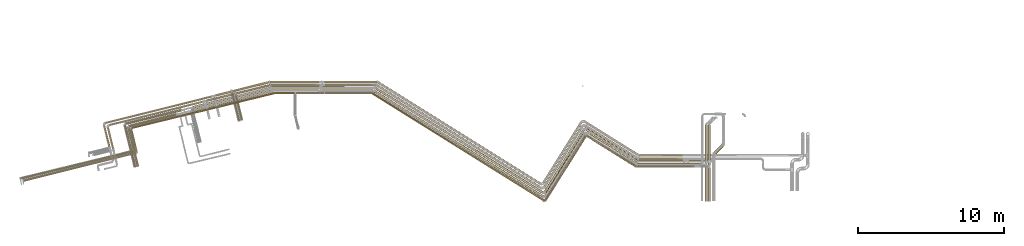
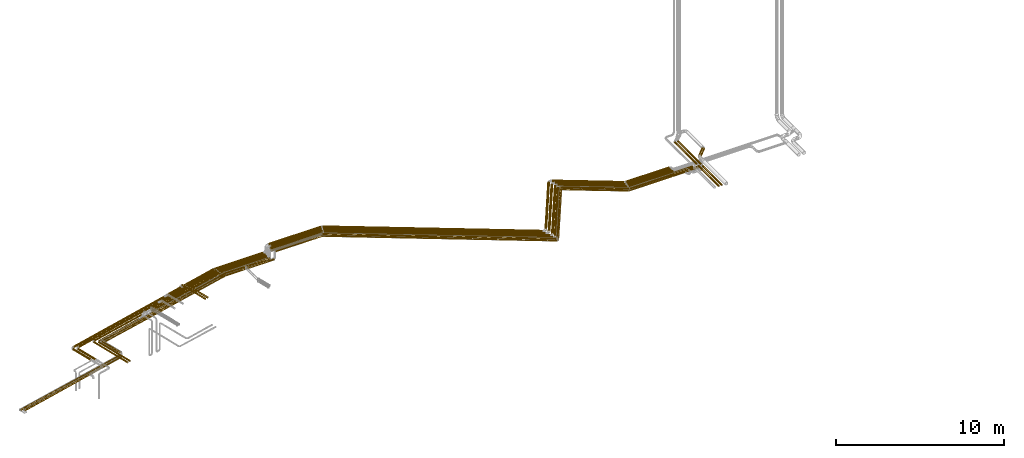
# One storey, part 1 of 93: 65 coverings.
"""IFC2X3 building model written with IfcOpenShell, lengths in millimetres."""

from ifc_helpers import new_model, entity, si_unit, converted_unit, derived_unit, direction, frame, origin, origin_2d_with_axis, place, context, subcontext, project, spatial, circle, extrude, element, save


model = new_model("IFC2X3")

# Units and contexts
model_context = context("Model", 3, precision=0.01, world=origin(), true_north=direction((6.12303176911189e-17, 1.0)))
body_context = subcontext(model_context, "Body", "Model", "MODEL_VIEW")
ifc_project = project(units=[si_unit("LENGTHUNIT", "METRE", prefix="MILLI"), si_unit("AREAUNIT", "SQUARE_METRE"), si_unit("VOLUMEUNIT", "CUBIC_METRE"), converted_unit("PLANEANGLEUNIT", "DEGREE", entity("IfcRatioMeasure", 0.0174532925199433), si_unit("PLANEANGLEUNIT", "RADIAN"), dimensions=[0, 0, 0, 0, 0, 0, 0]), si_unit("MASSUNIT", "GRAM", prefix="KILO"), derived_unit("MASSDENSITYUNIT", [(si_unit("MASSUNIT", "GRAM", prefix="KILO"), 1), (si_unit("LENGTHUNIT", "METRE"), -3)]), derived_unit("MOMENTOFINERTIAUNIT", [(si_unit("LENGTHUNIT", "METRE"), 4)]), si_unit("TIMEUNIT", "SECOND"), si_unit("FREQUENCYUNIT", "HERTZ"), si_unit("THERMODYNAMICTEMPERATUREUNIT", "DEGREE_CELSIUS"), derived_unit("THERMALTRANSMITTANCEUNIT", [(si_unit("MASSUNIT", "GRAM", prefix="KILO"), 1), (si_unit("THERMODYNAMICTEMPERATUREUNIT", "KELVIN"), -1), (si_unit("TIMEUNIT", "SECOND"), -3)]), derived_unit("VOLUMETRICFLOWRATEUNIT", [(si_unit("LENGTHUNIT", "METRE"), 3), (si_unit("TIMEUNIT", "SECOND"), -1)]), derived_unit("MASSFLOWRATEUNIT", [(si_unit("MASSUNIT", "GRAM", prefix="KILO"), 1), (si_unit("TIMEUNIT", "SECOND"), -1)]), derived_unit("ROTATIONALFREQUENCYUNIT", [(si_unit("TIMEUNIT", "SECOND"), -1)]), si_unit("ELECTRICCURRENTUNIT", "AMPERE"), si_unit("ELECTRICVOLTAGEUNIT", "VOLT"), si_unit("POWERUNIT", "WATT"), si_unit("FORCEUNIT", "NEWTON", prefix="KILO"), si_unit("ILLUMINANCEUNIT", "LUX"), si_unit("LUMINOUSFLUXUNIT", "LUMEN"), si_unit("LUMINOUSINTENSITYUNIT", "CANDELA"), derived_unit("USERDEFINED", [(si_unit("MASSUNIT", "GRAM", prefix="KILO"), -1), (si_unit("LENGTHUNIT", "METRE"), -2), (si_unit("TIMEUNIT", "SECOND"), 3), (si_unit("LUMINOUSFLUXUNIT", "LUMEN"), 1)]), derived_unit("LINEARVELOCITYUNIT", [(si_unit("LENGTHUNIT", "METRE"), 1), (si_unit("TIMEUNIT", "SECOND"), -1)]), si_unit("PRESSUREUNIT", "PASCAL"), derived_unit("USERDEFINED", [(si_unit("LENGTHUNIT", "METRE"), -2), (si_unit("MASSUNIT", "GRAM", prefix="KILO"), 1), (si_unit("TIMEUNIT", "SECOND"), -2)]), derived_unit("LINEARFORCEUNIT", [(si_unit("MASSUNIT", "GRAM", prefix="KILO"), 1), (si_unit("LENGTHUNIT", "METRE"), 1), (si_unit("TIMEUNIT", "SECOND"), -2), (si_unit("LENGTHUNIT", "METRE"), -1)]), derived_unit("PLANARFORCEUNIT", [(si_unit("MASSUNIT", "GRAM", prefix="KILO"), 1), (si_unit("LENGTHUNIT", "METRE"), 1), (si_unit("TIMEUNIT", "SECOND"), -2), (si_unit("LENGTHUNIT", "METRE"), -2)])], contexts=[model_context])

# Site, building, storey
site_placement = place(None, origin())
site = spatial("IfcSite", under=ifc_project, at=site_placement, CompositionType="ELEMENT")
building_placement = place(site_placement, origin())
building = spatial("IfcBuilding", under=site, at=building_placement, CompositionType="ELEMENT")
storey_placement = place(building_placement, frame((0.0, 0.0, -4200.0)))
storey = spatial("IfcBuildingStorey", under=building, at=storey_placement, CompositionType="ELEMENT", Elevation=-4200.0)

# Coverings
covering_1_placement = place(storey_placement, frame((16223.6, 8804.96, 2914.66)))
element("IfcCovering", 1, at=covering_1_placement, inside=storey, Name=":ADSK_", ObjectType=":ADSK_", PredefinedType="INSULATION", context=body_context, shape_type="SweptSolid", body=[
    extrude(circle(Radius=84.5, at=origin_2d_with_axis()), frame((3445.16, 73.26, 86.1), z_axis=(-0.848048096872166, 0.529919263087781, 0.0), x_axis=(-0.529919263087781, -0.848048096872166, 0.0)), (0.0, 0.0, 1.0), 4007.77716045076),
])
covering_2_placement = place(storey_placement, frame((13365.87, 6651.78, 2914.66)))
element("IfcCovering", 2, at=covering_2_placement, inside=storey, Name=":ADSK_", ObjectType=":ADSK_", PredefinedType="INSULATION", context=body_context, shape_type="SweptSolid", body=[
    extrude(circle(Radius=84.5, at=origin_2d_with_axis()), frame((73.26, 46.37, 86.1), z_axis=(0.529919264233208, 0.848048096156424, 0.0), x_axis=(0.848048096156424, -0.529919264233208, 0.0)), (0.0, 0.0, 1.0), 5029.99999999998),
])
covering_3_placement = place(storey_placement, frame((1670.12, 6586.73, 2913.9)))
element("IfcCovering", 3, at=covering_3_placement, inside=storey, Name=":ADSK_", ObjectType=":ADSK_", PredefinedType="INSULATION", context=body_context, shape_type="SweptSolid", body=[
    extrude(circle(Radius=84.5, at=origin_2d_with_axis()), frame((11603.65, 73.26, 86.85), z_axis=(-0.848048094870504, 0.529919263429674, -5.5069602747006e-05), x_axis=(0.529919264233207, 0.848048096156425, 0.0)), (0.0, 0.0, 1.0), 13628.0909050597),
])
covering_4_placement = place(storey_placement, frame((-1871.09, 13813.91, 2913.9)))
element("IfcCovering", 4, at=covering_4_placement, inside=storey, Name=":ADSK_", ObjectType=":ADSK_", PredefinedType="INSULATION", context=body_context, shape_type="SweptSolid", body=[
    extrude(circle(Radius=84.5, at=origin_2d_with_axis()), frame((0.0, 86.1, 86.1), z_axis=(1.0, 0.0, -7.50758540454034e-07), x_axis=(0.0, -1.0, 0.0)), (0.0, 0.0, 1.0), 3523.99516441944),
])
covering_5_placement = place(storey_placement, frame((19732.35, 8773.89, 2914.66)))
element("IfcCovering", 5, at=covering_5_placement, inside=storey, Name=":ADSK_", ObjectType=":ADSK_", PredefinedType="INSULATION", context=body_context, shape_type="SweptSolid", body=[
    extrude(circle(Radius=84.5, at=origin_2d_with_axis()), frame((0.0, 86.1, 86.1), z_axis=(1.0, 0.0, 0.0), x_axis=(0.0, -1.0, 0.0)), (0.0, 0.0, 1.0), 4364.44138685684),
])
covering_6_placement = place(storey_placement, frame((24958.04, 9544.49, 2891.9)))
element("IfcCovering", 6, at=covering_6_placement, inside=storey, Name=":ADSK_", ObjectType=":ADSK_", PredefinedType="INSULATION", context=body_context, shape_type="SweptSolid", body=[
    extrude(circle(Radius=106.5, at=origin_2d_with_axis()), frame((76.9, 76.9, 108.1), z_axis=(0.707106781186553, 0.707106781186542, 0.0), x_axis=(-0.707106781186542, 0.707106781186553, 0.0)), (0.0, 0.0, 1.0), 775.735931288089),
])
covering_7_placement = place(storey_placement, frame((19790.5, 8975.05, 2910.91)))
element("IfcCovering", 7, at=covering_7_placement, inside=storey, Name=":ADSK_", ObjectType=":ADSK_", PredefinedType="INSULATION", context=body_context, shape_type="SweptSolid", body=[
    extrude(circle(Radius=84.5, at=origin_2d_with_axis()), frame((0.0, 86.1, 86.1), z_axis=(1.0, 0.0, 0.0), x_axis=(0.0, 1.0, 0.0)), (0.0, 0.0, 1.0), 3082.63986313707),
])
covering_8_placement = place(storey_placement, frame((16181.84, 9006.12, 2910.91)))
element("IfcCovering", 8, at=covering_8_placement, inside=storey, Name=":ADSK_", ObjectType=":ADSK_", PredefinedType="INSULATION", context=body_context, shape_type="SweptSolid", body=[
    extrude(circle(Radius=84.5, at=origin_2d_with_axis()), frame((3545.07, 73.26, 86.1), z_axis=(-0.848048096872165, 0.529919263087784, 0.0), x_axis=(-0.529919263087784, -0.848048096872165, 0.0)), (0.0, 0.0, 1.0), 4125.59056056346),
])
covering_9_placement = place(storey_placement, frame((13334.7, 6932.33, 2910.91)))
element("IfcCovering", 9, at=covering_9_placement, inside=storey, Name=":ADSK_", ObjectType=":ADSK_", PredefinedType="INSULATION", context=body_context, shape_type="SweptSolid", body=[
    extrude(circle(Radius=84.5, at=origin_2d_with_axis()), frame((73.26, 46.37, 86.1), z_axis=(0.529919264233209, 0.848048096156423, 0.0), x_axis=(0.848048096156423, -0.529919264233209, 0.0)), (0.0, 0.0, 1.0), 5010.0017049427),
])
covering_10_placement = place(storey_placement, frame((1774.02, 6867.28, 2910.91)))
element("IfcCovering", 10, at=covering_10_placement, inside=storey, Name=":ADSK_", ObjectType=":ADSK_", PredefinedType="INSULATION", context=body_context, shape_type="SweptSolid", body=[
    extrude(circle(Radius=84.5, at=origin_2d_with_axis()), frame((11468.58, 73.26, 86.1), z_axis=(-0.848048096156424, 0.529919264233208, 0.0), x_axis=(0.0, 0.0, -1.0)), (0.0, 0.0, 1.0), 13468.8235901615),
])
covering_11_placement = place(storey_placement, frame((-1834.92, 14010.06, 2910.94)))
element("IfcCovering", 11, at=covering_11_placement, inside=storey, Name=":ADSK_", ObjectType=":ADSK_", PredefinedType="INSULATION", context=body_context, shape_type="SweptSolid", body=[
    extrude(circle(Radius=84.5, at=origin_2d_with_axis()), frame((3591.85, 86.1, 86.1), z_axis=(-0.99999896917087, 0.00107763060458495, 0.000948878009774168), x_axis=(-0.00107763108971813, -0.999999419355449, 0.0)), (0.0, 0.0, 1.0), 3590.17075330023),
])
covering_12_placement = place(storey_placement, frame((-7764.06, 13646.82, 2416.82)))
element("IfcCovering", 12, at=covering_12_placement, inside=storey, Name=":ADSK_", ObjectType=":ADSK_", PredefinedType="INSULATION", context=body_context, shape_type="SweptSolid", body=[
    extrude(circle(Radius=81.5, at=origin_2d_with_axis()), frame((20.9, 80.78, 83.1), z_axis=(0.971553061175066, 0.236821975409198, 3.58419250346389e-05), x_axis=(0.236821975561314, -0.971553061799116, 0.0)), (0.0, 0.0, 1.0), 2394.20471743284),
])
covering_13_placement = place(storey_placement, frame((-16451.83, 11492.29, 2429.32)))
element("IfcCovering", 13, at=covering_13_placement, inside=storey, Name=":ADSK_", ObjectType=":ADSK_", PredefinedType="INSULATION", context=body_context, shape_type="SweptSolid", body=[
    extrude(circle(Radius=69.0, at=origin_2d_with_axis()), frame((18.29, 68.55, 70.6), z_axis=(0.970295726276005, 0.241921895599632, 0.0), x_axis=(-0.241921895599632, 0.970295726276005, 0.0)), (0.0, 0.0, 1.0), 6535.06575644785),
])
covering_14_placement = place(storey_placement, frame((-7831.89, 11898.55, 2654.9)))
element("IfcCovering", 14, at=covering_14_placement, inside=storey, Name=":ADSK_", ObjectType=":ADSK_", PredefinedType="INSULATION", context=body_context, shape_type="SweptSolid", body=[
    extrude(circle(Radius=43.5, at=origin_2d_with_axis()), frame((43.8, 1740.55, 45.1), z_axis=(0.241921895599631, -0.970295726276006, 0.0), x_axis=(0.970295726276006, 0.241921895599631, 0.0)), (0.0, 0.0, 1.0), 1781.33959077582),
])
covering_15_placement = place(storey_placement, frame((-9803.41, 13138.56, 2416.82)))
element("IfcCovering", 15, at=covering_15_placement, inside=storey, Name=":ADSK_", ObjectType=":ADSK_", PredefinedType="INSULATION", context=body_context, shape_type="SweptSolid", body=[
    extrude(circle(Radius=81.5, at=origin_2d_with_axis()), frame((21.31, 80.67, 83.1), z_axis=(0.970295726276001, 0.241921895599651, 0.0), x_axis=(-0.171064612896004, 0.686102687806091, 0.707106781186546)), (0.0, 0.0, 1.0), 1971.35839123397),
])
covering_16_placement = place(storey_placement, frame((-5372.07, 14216.91, 2416.9)))
element("IfcCovering", 16, at=covering_16_placement, inside=storey, Name=":ADSK_", ObjectType=":ADSK_", PredefinedType="INSULATION", context=body_context, shape_type="SweptSolid", body=[
    extrude(circle(Radius=81.5, at=origin_2d_with_axis()), frame((0.0, 83.1, 83.1), z_axis=(1.0, 0.0, 0.0), x_axis=(0.0, 1.0, 0.0)), (0.0, 0.0, 1.0), 3329.8857023589),
])
covering_17_placement = place(storey_placement, frame((1863.72, 7196.14, 2916.9)))
element("IfcCovering", 17, at=covering_17_placement, inside=storey, Name=":ADSK_", ObjectType=":ADSK_", PredefinedType="INSULATION", context=body_context, shape_type="SweptSolid", body=[
    extrude(circle(Radius=81.5, at=origin_2d_with_axis()), frame((44.78, 7074.99, 83.1), z_axis=(0.848048096156426, -0.529919264233205, 0.0), x_axis=(0.529919264233205, 0.848048096156426, 0.0)), (0.0, 0.0, 1.0), 13217.6368280217),
])
covering_18_placement = place(storey_placement, frame((13308.79, 7282.51, 2916.9)))
element("IfcCovering", 18, at=covering_18_placement, inside=storey, Name=":ADSK_", ObjectType=":ADSK_", PredefinedType="INSULATION", context=body_context, shape_type="SweptSolid", body=[
    extrude(circle(Radius=81.5, at=origin_2d_with_axis()), frame((70.71, 44.78, 83.1), z_axis=(0.529919264233208, 0.848048096156424, 0.0), x_axis=(-0.848048096156424, 0.529919264233208, 0.0)), (0.0, 0.0, 1.0), 4839.99999995205),
])
covering_19_placement = place(storey_placement, frame((16161.34, 9212.9, 2916.9)))
element("IfcCovering", 19, at=covering_19_placement, inside=storey, Name=":ADSK_", ObjectType=":ADSK_", PredefinedType="INSULATION", context=body_context, shape_type="SweptSolid", body=[
    extrude(circle(Radius=81.5, at=origin_2d_with_axis()), frame((3579.42, 70.71, 83.1), z_axis=(-0.848048096156425, 0.529919264233206, 0.0), x_axis=(0.529919264233206, 0.848048096156425, 0.0)), (0.0, 0.0, 1.0), 4167.96244380158),
])
covering_20_placement = place(storey_placement, frame((19841.45, 9171.64, 2916.9)))
element("IfcCovering", 20, at=covering_20_placement, inside=storey, Name=":ADSK_", ObjectType=":ADSK_", PredefinedType="INSULATION", context=body_context, shape_type="SweptSolid", body=[
    extrude(circle(Radius=81.5, at=origin_2d_with_axis()), frame((0.0, 83.1, 83.1), z_axis=(1.0, 0.0, 0.0), x_axis=(0.0, 1.0, 0.0)), (0.0, 0.0, 1.0), 3011.72234269005),
])
covering_21_placement = place(storey_placement, frame((24403.45, 8937.14, 2935.4)))
element("IfcCovering", 21, at=covering_21_placement, inside=storey, Name=":ADSK_", ObjectType=":ADSK_", PredefinedType="INSULATION", context=body_context, shape_type="SweptSolid", body=[
    extrude(circle(Radius=63.0, at=origin_2d_with_axis()), frame((64.6, 0.0, 64.6), z_axis=(0.0, 1.0, 0.0), x_axis=(-1.0, 0.0, 0.0)), (0.0, 0.0, 1.0), 2647.17830176069),
])
covering_22_placement = place(storey_placement, frame((24403.45, 6345.74, 2935.4)))
element("IfcCovering", 22, at=covering_22_placement, inside=storey, Name=":ADSK_", ObjectType=":ADSK_", PredefinedType="INSULATION", context=body_context, shape_type="SweptSolid", body=[
    extrude(circle(Radius=63.0, at=origin_2d_with_axis()), frame((64.6, 0.0, 64.6), z_axis=(0.0, 1.0, 0.0), x_axis=(-1.0, 0.0, 0.0)), (0.0, 0.0, 1.0), 2439.40034200199),
])
covering_23_placement = place(storey_placement, frame((19661.55, 8660.55, 2892.25)))
element("IfcCovering", 23, at=covering_23_placement, inside=storey, Name=":ADSK_", ObjectType=":ADSK_", PredefinedType="INSULATION", context=body_context, shape_type="SweptSolid", body=[
    extrude(circle(Radius=49.0, at=origin_2d_with_axis()), frame((0.0, 50.6, 50.6), z_axis=(1.0, 0.0, 0.0), x_axis=(0.0, -1.0, 0.0)), (0.0, 0.0, 1.0), 3805.04533999816),
])
covering_24_placement = place(storey_placement, frame((16256.83, 8676.65, 2892.25)))
element("IfcCovering", 24, at=covering_24_placement, inside=storey, Name=":ADSK_", ObjectType=":ADSK_", PredefinedType="INSULATION", context=body_context, shape_type="SweptSolid", body=[
    extrude(circle(Radius=49.0, at=origin_2d_with_axis()), frame((3374.52, 43.15, 50.6), z_axis=(-0.848048096872167, 0.529919263087781, 0.0), x_axis=(-0.529919263087781, -0.848048096872167, 0.0)), (0.0, 0.0, 1.0), 3946.65551305345),
])
covering_25_placement = place(storey_placement, frame((13407.19, 6355.78, 2892.25)))
element("IfcCovering", 25, at=covering_25_placement, inside=storey, Name=":ADSK_", ObjectType=":ADSK_", PredefinedType="INSULATION", context=body_context, shape_type="SweptSolid", body=[
    extrude(circle(Radius=49.0, at=origin_2d_with_axis()), frame((43.15, 27.56, 50.6), z_axis=(0.529919264233211, 0.848048096156422, 0.0), x_axis=(0.848048096156422, -0.529919264233211, 0.0)), (0.0, 0.0, 1.0), 5199.86161627023),
])
covering_26_placement = place(storey_placement, frame((1539.96, 6322.06, 2892.25)))
element("IfcCovering", 26, at=covering_26_placement, inside=storey, Name=":ADSK_", ObjectType=":ADSK_", PredefinedType="INSULATION", context=body_context, shape_type="SweptSolid", body=[
    extrude(circle(Radius=49.0, at=origin_2d_with_axis()), frame((27.56, 7419.28, 50.6), z_axis=(0.848048096156422, -0.529919264233212, 0.0), x_axis=(0.529919264233212, 0.848048096156422, 0.0)), (0.0, 0.0, 1.0), 13919.3436019751),
])
covering_27_placement = place(storey_placement, frame((-3645.84, 13699.41, 2342.25)))
element("IfcCovering", 27, at=covering_27_placement, inside=storey, Name=":ADSK_", ObjectType=":ADSK_", PredefinedType="INSULATION", context=body_context, shape_type="SweptSolid", body=[
    extrude(circle(Radius=49.0, at=origin_2d_with_axis()), frame((0.0, 50.6, 50.6), z_axis=(1.0, 0.0, 0.0), x_axis=(0.0, 1.0, 0.0)), (0.0, 0.0, 1.0), 1883.00000000001),
])
covering_28_placement = place(storey_placement, frame((-15000.07, 10033.67, 2342.25)))
element("IfcCovering", 28, at=covering_28_placement, inside=storey, Name=":ADSK_", ObjectType=":ADSK_", PredefinedType="INSULATION", context=body_context, shape_type="SweptSolid", body=[
    extrude(circle(Radius=49.0, at=origin_2d_with_axis()), frame((348.35, 13.05, 50.6), z_axis=(-0.233868385495283, 0.972268264557591, 0.0), x_axis=(-0.972268264557591, -0.233868385495283, 0.0)), (0.0, 0.0, 1.0), 1278.99033837842),
])
covering_29_placement = place(storey_placement, frame((24609.86, 8787.14, 2935.4)))
element("IfcCovering", 29, at=covering_29_placement, inside=storey, Name=":ADSK_", ObjectType=":ADSK_", PredefinedType="INSULATION", context=body_context, shape_type="SweptSolid", body=[
    extrude(circle(Radius=63.0, at=origin_2d_with_axis()), frame((64.6, 0.0, 64.6), z_axis=(0.0, 1.0, 0.0), x_axis=(-1.0, 0.0, 0.0)), (0.0, 0.0, 1.0), 2807.17830176069),
])
covering_30_placement = place(storey_placement, frame((24609.86, 6345.74, 2935.4)))
element("IfcCovering", 30, at=covering_30_placement, inside=storey, Name=":ADSK_", ObjectType=":ADSK_", PredefinedType="INSULATION", context=body_context, shape_type="SweptSolid", body=[
    extrude(circle(Radius=63.0, at=origin_2d_with_axis()), frame((64.6, 0.0, 64.6), z_axis=(0.0, 1.0, 0.0), x_axis=(-1.0, 0.0, 0.0)), (0.0, 0.0, 1.0), 2289.40034200199),
])
covering_31_placement = place(storey_placement, frame((19692.0, 8660.55, 3008.21)))
element("IfcCovering", 31, at=covering_31_placement, inside=storey, Name=":ADSK_", ObjectType=":ADSK_", PredefinedType="INSULATION", context=body_context, shape_type="SweptSolid", body=[
    extrude(circle(Radius=49.0, at=origin_2d_with_axis()), frame((0.0, 50.6, 50.6), z_axis=(1.0, 0.0, 0.0), x_axis=(0.0, -1.0, 0.0)), (0.0, 0.0, 1.0), 3960.04533999814),
])
covering_32_placement = place(storey_placement, frame((16236.4, 8676.65, 3008.21)))
element("IfcCovering", 32, at=covering_32_placement, inside=storey, Name=":ADSK_", ObjectType=":ADSK_", PredefinedType="INSULATION", context=body_context, shape_type="SweptSolid", body=[
    extrude(circle(Radius=49.0, at=origin_2d_with_axis()), frame((27.56, 2166.35, 50.6), z_axis=(0.848048096872167, -0.529919263087781, 0.0), x_axis=(-0.529919263087781, -0.848048096872167, 0.0)), (0.0, 0.0, 1.0), 4006.65551305341),
])
covering_33_placement = place(storey_placement, frame((13378.21, 6373.89, 3008.21)))
element("IfcCovering", 33, at=covering_33_placement, inside=storey, Name=":ADSK_", ObjectType=":ADSK_", PredefinedType="INSULATION", context=body_context, shape_type="SweptSolid", body=[
    extrude(circle(Radius=49.0, at=origin_2d_with_axis()), frame((43.15, 27.56, 50.6), z_axis=(0.52991926423321, 0.848048096156423, 0.0), x_axis=(0.848048096156423, -0.52991926423321, 0.0)), (0.0, 0.0, 1.0), 5215.99892406455),
])
covering_34_placement = place(storey_placement, frame((1540.46, 6340.17, 3008.21)))
element("IfcCovering", 34, at=covering_34_placement, inside=storey, Name=":ADSK_", ObjectType=":ADSK_", PredefinedType="INSULATION", context=body_context, shape_type="SweptSolid", body=[
    extrude(circle(Radius=49.0, at=origin_2d_with_axis()), frame((27.56, 7401.17, 50.6), z_axis=(0.848038093311225, -0.529935271795586, 0.0), x_axis=(-0.529935271795586, -0.848038093311225, 0.0)), (0.0, 0.0, 1.0), 13884.7471169057),
])
covering_35_placement = place(storey_placement, frame((-5093.58, 13699.41, 2508.21)))
element("IfcCovering", 35, at=covering_35_placement, inside=storey, Name=":ADSK_", ObjectType=":ADSK_", PredefinedType="INSULATION", context=body_context, shape_type="SweptSolid", body=[
    extrude(circle(Radius=49.0, at=origin_2d_with_axis()), frame((0.0, 50.6, 50.6), z_axis=(1.0, 0.0, 0.0), x_axis=(0.0, 1.0, 0.0)), (0.0, 0.0, 1.0), 1333.74030890236),
])
covering_36_placement = place(storey_placement, frame((-15000.09, 9718.18, 2508.21)))
element("IfcCovering", 36, at=covering_36_placement, inside=storey, Name=":ADSK_", ObjectType=":ADSK_", PredefinedType="INSULATION", context=body_context, shape_type="SweptSolid", body=[
    extrude(circle(Radius=49.0, at=origin_2d_with_axis()), frame((49.24, 1572.16, 50.6), z_axis=(0.233646720181625, -0.9723215569699, 0.0), x_axis=(-0.9723215569699, -0.233646720181625, 0.0)), (0.0, 0.0, 1.0), 1603.49585906828),
])
covering_37_placement = place(storey_placement, frame((-8007.16, 13793.55, 2416.9)))
element("IfcCovering", 37, at=covering_37_placement, inside=storey, Name=":ADSK_", ObjectType=":ADSK_", PredefinedType="INSULATION", context=body_context, shape_type="SweptSolid", body=[
    extrude(circle(Radius=81.5, at=origin_2d_with_axis()), frame((21.31, 80.67, 83.1), z_axis=(0.970295726276005, 0.241921895599635, 0.0), x_axis=(0.241921895599635, -0.970295726276005, 0.0)), (0.0, 0.0, 1.0), 2563.34327595366),
])
covering_38_placement = place(storey_placement, frame((-16877.1, 10055.95, 2429.4)))
element("IfcCovering", 38, at=covering_38_placement, inside=storey, Name=":ADSK_", ObjectType=":ADSK_", PredefinedType="INSULATION", context=body_context, shape_type="SweptSolid", body=[
    extrude(circle(Radius=69.0, at=origin_2d_with_axis()), frame((68.54, 1463.93, 70.6), z_axis=(0.242135671523188, -0.970242400937011, 0.0), x_axis=(0.970242400937011, 0.242135671523188, 0.0)), (0.0, 0.0, 1.0), 1489.96956280194),
])
covering_39_placement = place(storey_placement, frame((-16717.59, 11633.17, 2429.4)))
element("IfcCovering", 39, at=covering_39_placement, inside=storey, Name=":ADSK_", ObjectType=":ADSK_", PredefinedType="INSULATION", context=body_context, shape_type="SweptSolid", body=[
    extrude(circle(Radius=69.0, at=origin_2d_with_axis()), frame((18.29, 68.55, 70.6), z_axis=(0.970295726275999, 0.241921895599659, 0.0), x_axis=(-0.241921895599659, 0.970295726275999, 0.0)), (0.0, 0.0, 1.0), 7450.83630867599),
])
covering_40_placement = place(storey_placement, frame((-9180.6, 13500.98, 2416.9)))
element("IfcCovering", 40, at=covering_40_placement, inside=storey, Name=":ADSK_", ObjectType=":ADSK_", PredefinedType="INSULATION", context=body_context, shape_type="SweptSolid", body=[
    extrude(circle(Radius=81.5, at=origin_2d_with_axis()), frame((21.31, 80.67, 83.1), z_axis=(0.970295726276007, 0.241921895599625, 0.0), x_axis=(0.171064612895999, -0.686102687806064, -0.707106781186573)), (0.0, 0.0, 1.0), 1079.36675916112),
])
covering_41_placement = place(storey_placement, frame((-5452.68, 14416.91, 2416.9)))
element("IfcCovering", 41, at=covering_41_placement, inside=storey, Name=":ADSK_", ObjectType=":ADSK_", PredefinedType="INSULATION", context=body_context, shape_type="SweptSolid", body=[
    extrude(circle(Radius=81.5, at=origin_2d_with_axis()), frame((0.0, 83.1, 83.1), z_axis=(1.0, 0.0, 0.0), x_axis=(0.0, 1.0, 0.0)), (0.0, 0.0, 1.0), 3370.91944682417),
])
covering_42_placement = place(storey_placement, frame((1944.14, 7482.1, 2916.9)))
element("IfcCovering", 42, at=covering_42_placement, inside=storey, Name=":ADSK_", ObjectType=":ADSK_", PredefinedType="INSULATION", context=body_context, shape_type="SweptSolid", body=[
    extrude(circle(Radius=81.5, at=origin_2d_with_axis()), frame((11116.4, 70.71, 83.1), z_axis=(-0.848048096156424, 0.529919264233209, 0.0), x_axis=(0.529919264233209, 0.848048096156424, 0.0)), (0.0, 0.0, 1.0), 13055.4167034884),
])
covering_43_placement = place(storey_placement, frame((13251.65, 7568.47, 2916.9)))
element("IfcCovering", 43, at=covering_43_placement, inside=storey, Name=":ADSK_", ObjectType=":ADSK_", PredefinedType="INSULATION", context=body_context, shape_type="SweptSolid", body=[
    extrude(circle(Radius=81.5, at=origin_2d_with_axis()), frame((70.71, 44.78, 83.1), z_axis=(0.52991926423321, 0.848048096156423, 0.0), x_axis=(-0.848048096156423, 0.52991926423321, 0.0)), (0.0, 0.0, 1.0), 4839.99999992639),
])
covering_44_placement = place(storey_placement, frame((16104.2, 9432.3, 2916.9)))
element("IfcCovering", 44, at=covering_44_placement, inside=storey, Name=":ADSK_", ObjectType=":ADSK_", PredefinedType="INSULATION", context=body_context, shape_type="SweptSolid", body=[
    extrude(circle(Radius=81.5, at=origin_2d_with_axis()), frame((3685.94, 70.71, 83.1), z_axis=(-0.848048096156423, 0.529919264233209, 0.0), x_axis=(0.529919264233209, 0.848048096156423, 0.0)), (0.0, 0.0, 1.0), 4293.57017112024),
])
covering_45_placement = place(storey_placement, frame((19890.82, 9391.04, 2916.9)))
element("IfcCovering", 45, at=covering_45_placement, inside=storey, Name=":ADSK_", ObjectType=":ADSK_", PredefinedType="INSULATION", context=body_context, shape_type="SweptSolid", body=[
    extrude(circle(Radius=81.5, at=origin_2d_with_axis()), frame((0.0, 83.1, 83.1), z_axis=(1.0, 0.0, 0.0), x_axis=(0.0, 1.0, 0.0)), (0.0, 0.0, 1.0), 2962.34690637158),
])
covering_46_placement = place(storey_placement, frame((-14922.13, 11309.83, 2508.21)))
element("IfcCovering", 46, at=covering_46_placement, inside=storey, Name=":ADSK_", ObjectType=":ADSK_", PredefinedType="INSULATION", context=body_context, shape_type="SweptSolid", body=[
    extrude(circle(Radius=49.0, at=origin_2d_with_axis()), frame((13.2, 49.2, 50.6), z_axis=(0.971551074149834, 0.236830129667456, 0.0), x_axis=(-0.236830129667456, 0.971551074149834, 0.0)), (0.0, 0.0, 1.0), 10088.8628906297),
])
covering_47_placement = place(storey_placement, frame((-3645.84, 13699.41, 2508.21)))
element("IfcCovering", 47, at=covering_47_placement, inside=storey, Name=":ADSK_", ObjectType=":ADSK_", PredefinedType="INSULATION", context=body_context, shape_type="SweptSolid", body=[
    extrude(circle(Radius=49.0, at=origin_2d_with_axis()), frame((0.0, 50.6, 50.6), z_axis=(1.0, 0.0, 0.0), x_axis=(0.0, 1.0, 0.0)), (0.0, 0.0, 1.0), 1583.00000000001),
])
covering_48_placement = place(storey_placement, frame((-5093.23, 13699.41, 2342.25)))
element("IfcCovering", 48, at=covering_48_placement, inside=storey, Name=":ADSK_", ObjectType=":ADSK_", PredefinedType="INSULATION", context=body_context, shape_type="SweptSolid", body=[
    extrude(circle(Radius=49.0, at=origin_2d_with_axis()), frame((0.0, 50.6, 50.6), z_axis=(1.0, 0.0, 0.0), x_axis=(0.0, -1.0, 0.0)), (0.0, 0.0, 1.0), 1333.38964173774),
])
covering_49_placement = place(storey_placement, frame((-8074.57, 11850.17, 2654.9)))
element("IfcCovering", 49, at=covering_49_placement, inside=storey, Name=":ADSK_", ObjectType=":ADSK_", PredefinedType="INSULATION", context=body_context, shape_type="SweptSolid", body=[
    extrude(circle(Radius=43.5, at=origin_2d_with_axis()), frame((43.8, 1935.56, 45.1), z_axis=(0.241921895599632, -0.970295726276005, 0.0), x_axis=(0.970295726276005, 0.241921895599632, 0.0)), (0.0, 0.0, 1.0), 1982.32667790187),
])
covering_50_placement = place(storey_placement, frame((-10754.69, 12682.28, 2414.21)))
element("IfcCovering", 50, at=covering_50_placement, inside=storey, Name=":ADSK_", ObjectType=":ADSK_", PredefinedType="INSULATION", context=body_context, shape_type="SweptSolid", body=[
    extrude(circle(Radius=84.5, at=origin_2d_with_axis()), frame((22.04, 83.59, 86.1), z_axis=(0.970295726405392, 0.241921895080689, 0.0), x_axis=(-0.241921895080689, 0.970295726405392, 0.0)), (0.0, 0.0, 1.0), 5499.99479458199),
])
covering_51_placement = place(storey_placement, frame((-1701.76, 14416.91, 2916.9)))
element("IfcCovering", 51, at=covering_51_placement, inside=storey, Name=":ADSK_", ObjectType=":ADSK_", PredefinedType="INSULATION", context=body_context, shape_type="SweptSolid", body=[
    extrude(circle(Radius=81.5, at=origin_2d_with_axis()), frame((0.0, 83.1, 83.1), z_axis=(1.0, 0.0, 0.0), x_axis=(0.0, -1.0, 0.0)), (0.0, 0.0, 1.0), 3590.0),
])
covering_52_placement = place(storey_placement, frame((-1662.18, 14216.91, 2916.9)))
element("IfcCovering", 52, at=covering_52_placement, inside=storey, Name=":ADSK_", ObjectType=":ADSK_", PredefinedType="INSULATION", context=body_context, shape_type="SweptSolid", body=[
    extrude(circle(Radius=81.5, at=origin_2d_with_axis()), frame((0.0, 83.1, 83.1), z_axis=(1.0, 0.0, 0.0), x_axis=(0.0, -1.0, 0.0)), (0.0, 0.0, 1.0), 3470.00000000001),
])
covering_53_placement = place(storey_placement, frame((-5367.0, 14013.91, 2414.21)))
element("IfcCovering", 53, at=covering_53_placement, inside=storey, Name=":ADSK_", ObjectType=":ADSK_", PredefinedType="INSULATION", context=body_context, shape_type="SweptSolid", body=[
    extrude(circle(Radius=84.5, at=origin_2d_with_axis()), frame((0.0, 86.1, 86.1), z_axis=(1.0, 0.0, 0.0), x_axis=(0.0, -1.0, 0.0)), (0.0, 0.0, 1.0), 3293.65038874736),
])
covering_54_placement = place(storey_placement, frame((-5347.47, 13813.91, 2417.55)))
element("IfcCovering", 54, at=covering_54_placement, inside=storey, Name=":ADSK_", ObjectType=":ADSK_", PredefinedType="INSULATION", context=body_context, shape_type="SweptSolid", body=[
    extrude(circle(Radius=84.5, at=origin_2d_with_axis()), frame((0.0, 86.1, 86.1), z_axis=(1.0, 0.0, 0.0), x_axis=(0.0, -1.0, 0.0)), (0.0, 0.0, 1.0), 3236.37312185862),
])
covering_55_placement = place(storey_placement, frame((-14922.11, 11309.75, 2342.25)))
element("IfcCovering", 55, at=covering_55_placement, inside=storey, Name=":ADSK_", ObjectType=":ADSK_", PredefinedType="INSULATION", context=body_context, shape_type="SweptSolid", body=[
    extrude(circle(Radius=49.0, at=origin_2d_with_axis()), frame((13.2, 49.2, 50.6), z_axis=(0.971551074149835, 0.23683012966745, 0.0), x_axis=(0.23683012966745, -0.971551074149835, 0.0)), (0.0, 0.0, 1.0), 10089.2038362497),
])
covering_56_placement = place(storey_placement, frame((-22517.29, 7842.38, 2242.25)))
element("IfcCovering", 56, at=covering_56_placement, inside=storey, Name=":ADSK_", ObjectType=":ADSK_", PredefinedType="INSULATION", context=body_context, shape_type="SweptSolid", body=[
    extrude(circle(Radius=49.0, at=origin_2d_with_axis()), frame((13.2, 49.2, 50.6), z_axis=(0.971553776633291, 0.236819042962322, 0.0), x_axis=(0.236819042962322, -0.971553776633291, 0.0)), (0.0, 0.0, 1.0), 8081.84246750568),
])
covering_57_placement = place(storey_placement, frame((-22332.11, 7692.93, 2242.25)))
element("IfcCovering", 57, at=covering_57_placement, inside=storey, Name=":ADSK_", ObjectType=":ADSK_", PredefinedType="INSULATION", context=body_context, shape_type="SweptSolid", body=[
    extrude(circle(Radius=49.0, at=origin_2d_with_axis()), frame((13.45, 49.14, 50.6), z_axis=(0.970295726276022, 0.241921895599564, 0.0), x_axis=(0.241921895599564, -0.970295726276022, 0.0)), (0.0, 0.0, 1.0), 7936.21539652437),
])
covering_58_placement = place(storey_placement, frame((-16611.43, 9922.49, 2429.32)))
element("IfcCovering", 58, at=covering_58_placement, inside=storey, Name=":ADSK_", ObjectType=":ADSK_", PredefinedType="INSULATION", context=body_context, shape_type="SweptSolid", body=[
    extrude(circle(Radius=69.0, at=origin_2d_with_axis()), frame((68.63, 1456.52, 70.6), z_axis=(0.237217705772623, -0.971456428815589, 0.000408632885785687), x_axis=(0.971456509922902, 0.237217725578031, 0.0)), (0.0, 0.0, 1.0), 1480.8209980526),
])
covering_59_placement = place(storey_placement, frame((-15430.13, 8695.49, 2444.24)))
element("IfcCovering", 59, at=covering_59_placement, inside=storey, Name=":ADSK_", ObjectType=":ADSK_", PredefinedType="INSULATION", context=body_context, shape_type="SweptSolid", body=[
    extrude(circle(Radius=55.0, at=origin_2d_with_axis()), frame((742.68, 14.53, 56.6), z_axis=(-0.235134964159672, 0.971962730061971, -3.31313153751575e-07), x_axis=(0.971962730062025, 0.235134964159685, 0.0)), (0.0, 0.0, 1.0), 2924.38590899762),
])
covering_60_placement = place(storey_placement, frame((-15184.02, 8742.55, 2443.14)))
element("IfcCovering", 60, at=covering_60_placement, inside=storey, Name=":ADSK_", ObjectType=":ADSK_", PredefinedType="INSULATION", context=body_context, shape_type="SweptSolid", body=[
    extrude(circle(Radius=55.0, at=origin_2d_with_axis()), frame((691.08, 14.52, 56.6), z_axis=(-0.235049086006718, 0.97198349611196, 0.000102241762859156), x_axis=(-2.96098066233066e-05, 9.80284178904075e-05, -0.999999994756844)), (0.0, 0.0, 1.0), 2705.93955189196),
])
covering_61_placement = place(storey_placement, frame((-15088.39, 11423.84, 2443.4)))
element("IfcCovering", 61, at=covering_61_placement, inside=storey, Name=":ADSK_", ObjectType=":ADSK_", PredefinedType="INSULATION", context=body_context, shape_type="SweptSolid", body=[
    extrude(circle(Radius=55.0, at=origin_2d_with_axis()), frame((14.9, 54.96, 56.61), z_axis=(0.970288537655733, 0.241950725704179, -5.01200914775057e-06), x_axis=(-0.241950725707218, 0.97028853766792, 0.0)), (0.0, 0.0, 1.0), 3275.77869410409),
])
covering_62_placement = place(storey_placement, frame((-15334.59, 11588.01, 2444.24)))
element("IfcCovering", 62, at=covering_62_placement, inside=storey, Name=":ADSK_", ObjectType=":ADSK_", PredefinedType="INSULATION", context=body_context, shape_type="SweptSolid", body=[
    extrude(circle(Radius=55.0, at=origin_2d_with_axis()), frame((14.62, 55.03, 56.6), z_axis=(0.971551075195952, 0.236830125178739, 9.66501229446896e-06), x_axis=(9.39005308691199e-06, 2.28896607166004e-06, -1.0)), (0.0, 0.0, 1.0), 3891.90294438014),
])
covering_63_placement = place(storey_placement, frame((23281.68, 8975.05, 2601.77)))
element("IfcCovering", 63, at=covering_63_placement, inside=storey, Name=":ADSK_", ObjectType=":ADSK_", PredefinedType="INSULATION", context=body_context, shape_type="SweptSolid", body=[
    extrude(circle(Radius=84.5, at=origin_2d_with_axis()), frame((0.0, 86.1, 86.1), z_axis=(1.0, 0.0, 0.0), x_axis=(0.0, -1.0, 0.0)), (0.0, 0.0, 1.0), 1332.01994670235),
])
covering_64_placement = place(storey_placement, frame((-10824.52, 12460.16, 2417.55)))
element("IfcCovering", 64, at=covering_64_placement, inside=storey, Name=":ADSK_", ObjectType=":ADSK_", PredefinedType="INSULATION", context=body_context, shape_type="SweptSolid", body=[
    extrude(circle(Radius=84.5, at=origin_2d_with_axis()), frame((22.04, 83.59, 86.1), z_axis=(0.970302633072812, 0.241894192265893, 0.0), x_axis=(0.241894192265893, -0.970302633072812, 0.0)), (0.0, 0.0, 1.0), 5592.05871780592),
])
covering_65_placement = place(storey_placement, frame((-1648.84, 13699.41, 2892.25)))
element("IfcCovering", 65, at=covering_65_placement, inside=storey, Name=":ADSK_", ObjectType=":ADSK_", PredefinedType="INSULATION", context=body_context, shape_type="SweptSolid", body=[
    extrude(circle(Radius=49.0, at=origin_2d_with_axis()), frame((0.0, 50.6, 50.6), z_axis=(1.0, 0.0, 0.0), x_axis=(0.0, -1.0, 0.0)), (0.0, 0.0, 1.0), 3186.15832154256),
])

save(model, "model.ifc")
